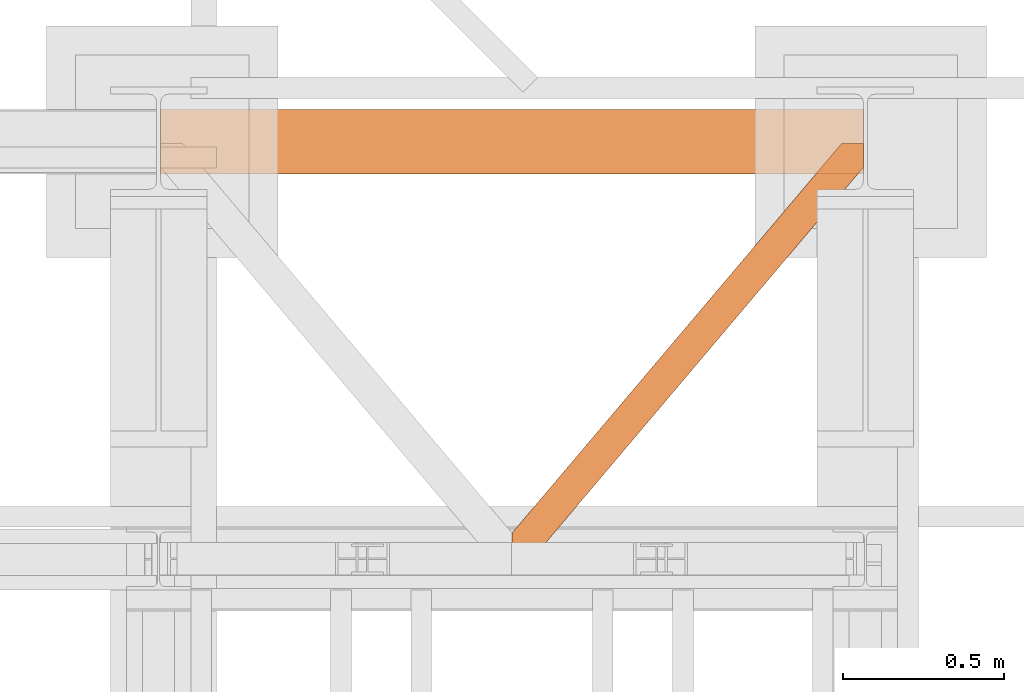
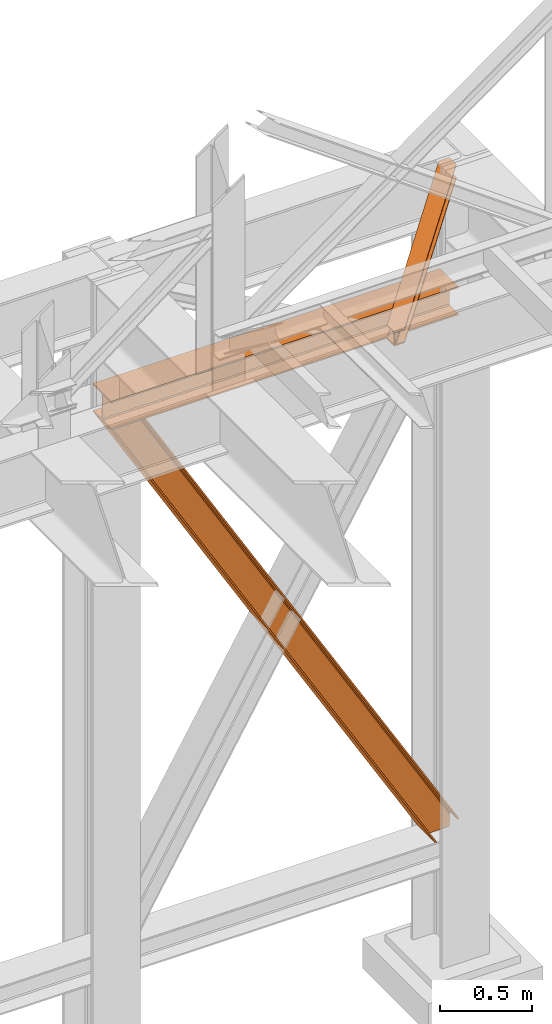
# One storey, part 198 of 208: 3 proxies.
"""IFC2X3 building model written with IfcOpenShell, lengths in millimetres."""

import ifcopenshell
import ifcopenshell.guid

model = None  # the IFC model being written
_history = None  # IfcOwnerHistory: only IFC2X3 demands one
_inside = {}  # id of a spatial element -> (the spatial element, [elements in it])
_under = {}  # id of a project, library or spatial element -> (it, [spatial elements below it])
_declared = {}  # id of a project -> (the project, [libraries it declares])
_typed = {}  # id of a type object -> (the type object, [elements of that type])
_made_of = {}  # id of a material, layer set ... -> (it, [elements and type objects made of it])


def new_model(schema):
    """Start an empty IFC model of exactly this schema.

    Asked for "IFC4X3", IfcOpenShell would pick the latest addendum, in which some entities
    have other attributes; the version numbers below select the first issue.
    IFC2X3 requires an IfcOwnerHistory on every rooted entity: one is made here for all.
    """
    global model, _history
    if schema == "IFC4X3":
        model = ifcopenshell.file(schema_version=(4, 3, 0, 0))
    else:
        model = ifcopenshell.file(schema=schema)
    _inside.clear()
    _under.clear()
    _declared.clear()
    _typed.clear()
    _made_of.clear()
    _history = None
    if model.schema == "IFC2X3":
        org = make("IfcOrganization", Name="unknown")
        user = make(
            "IfcPersonAndOrganization",
            ThePerson=make("IfcPerson", FamilyName="unknown"),
            TheOrganization=org,
        )
        app = make(
            "IfcApplication",
            ApplicationDeveloper=org,
            Version="unknown",
            ApplicationFullName="unknown",
            ApplicationIdentifier="unknown",
        )
        _history = make(
            "IfcOwnerHistory",
            OwningUser=user,
            OwningApplication=app,
            ChangeAction="ADDED",
            CreationDate=0,
        )
    return model


def make(cls, **values):
    """One entity of the class cls with the attributes given. An attribute that is None is left unset."""
    return model.create_entity(
        cls, **{name: value for name, value in values.items() if value is not None}
    )


def entity(cls, *values):
    """Any entity or typed value of the class cls, its attributes in the order of the schema. None: left unset."""
    e = model.create_entity(cls)
    for i, value in enumerate(values):
        if value is not None:
            e[i] = value
    return e


def rooted(cls, **values):
    """An entity with a GlobalId (a new one), such as an element, a storey or a relation."""
    return make(cls, GlobalId=ifcopenshell.guid.new(), OwnerHistory=_history, **values)


def si_unit(unit_type, name, prefix=None):
    """IfcSIUnit, for example si_unit("LENGTHUNIT", "METRE", prefix="MILLI")."""
    return make("IfcSIUnit", UnitType=unit_type, Prefix=prefix, Name=name)


def converted_unit(unit_type, name, factor, base, dimensions=None, offset=None):
    """IfcConversionBasedUnit, such as the inch: factor (a typed value) times the base unit."""
    return make(
        "IfcConversionBasedUnit"
        if offset is None
        else "IfcConversionBasedUnitWithOffset",
        ConversionOffset=offset,
        Dimensions=None
        if dimensions is None
        else entity("IfcDimensionalExponents", *dimensions),
        UnitType=unit_type,
        Name=name,
        ConversionFactor=make(
            "IfcMeasureWithUnit", ValueComponent=factor, UnitComponent=base
        ),
    )


def assignment(units):
    """IfcUnitAssignment: the units of a project."""
    return None if units is None else make("IfcUnitAssignment", Units=units)


def point(xyz):
    """IfcCartesianPoint."""
    return None if xyz is None else make("IfcCartesianPoint", Coordinates=xyz)


def direction(xyz):
    """IfcDirection."""
    return None if xyz is None else make("IfcDirection", DirectionRatios=xyz)


def frame(location, z_axis=None, x_axis=None):
    """IfcAxis2Placement3D, a coordinate frame: its origin and axes. An axis left out is left unset."""
    return make(
        "IfcAxis2Placement3D",
        Location=point(location),
        Axis=direction(z_axis),
        RefDirection=direction(x_axis),
    )


def origin():
    """The frame at (0, 0, 0) with its axes left unset."""
    return frame((0.0, 0.0, 0.0))


def origin_with_axes():
    """The frame at (0, 0, 0) with the z axis (0, 0, 1) and the x axis (1, 0, 0) written out."""
    return frame((0.0, 0.0, 0.0), z_axis=(0.0, 0.0, 1.0), x_axis=(1.0, 0.0, 0.0))


def place(relative_to, where):
    """IfcLocalPlacement: puts the frame where relative to a parent placement (None: the world)."""
    return make(
        "IfcLocalPlacement", PlacementRelTo=relative_to, RelativePlacement=where
    )


def context(
    kind, dimensions, precision=None, world=None, true_north=None, identifier=None
):
    """IfcGeometricRepresentationContext, for example the 3D "Model" context."""
    return make(
        "IfcGeometricRepresentationContext",
        ContextIdentifier=identifier,
        ContextType=kind,
        CoordinateSpaceDimension=dimensions,
        Precision=precision,
        WorldCoordinateSystem=world,
        TrueNorth=true_north,
    )


def subcontext(parent, identifier, kind, view, scale=None):
    """IfcGeometricRepresentationSubContext, for example "Body" below "Model"."""
    return make(
        "IfcGeometricRepresentationSubContext",
        ContextIdentifier=identifier,
        ContextType=kind,
        ParentContext=parent,
        TargetScale=scale,
        TargetView=view,
    )


def project(units=None, contexts=None):
    """IfcProject with its units and contexts."""
    return rooted(
        "IfcProject",
        Name="project",
        RepresentationContexts=contexts,
        UnitsInContext=assignment(units),
    )


def spatial(cls, under=None, at=None, **own):
    """A site, building, storey or space (cls), placed at a placement, below another one or the project."""
    s = rooted(cls, ObjectPlacement=at, **own)
    if under is not None:
        _under.setdefault(under.id(), (under, []))[1].append(s)
    return s


def faces_of(points, faces, orient=None, outer=None):
    """IfcFace entities. A face is a list of loops; a loop is a list of indices into points, from 0.

    orient and outer hold one flag for each loop. By default every Orientation is true, the
    first loop of a face is its IfcFaceOuterBound and the others are IfcFaceBound.
    """
    made = []
    for i, loops in enumerate(faces):
        bounds = []
        for j, loop in enumerate(loops):
            is_outer = j == 0 if outer is None else outer[i][j]
            bounds.append(
                make(
                    "IfcFaceOuterBound" if is_outer else "IfcFaceBound",
                    Bound=make("IfcPolyLoop", Polygon=[points[k] for k in loop]),
                    Orientation=True if orient is None else orient[i][j],
                )
            )
        made.append(make("IfcFace", Bounds=bounds))
    return made


def faceted_brep(points, faces, orient=None, outer=None, voids=None):
    """IfcFacetedBrep: a solid bounded by flat faces; with voids (closed shells), ...WithVoids."""
    shared = [point(p) for p in points]
    hull = make("IfcClosedShell", CfsFaces=faces_of(shared, faces, orient, outer))
    if voids is None:
        return make("IfcFacetedBrep", Outer=hull)
    return make(
        "IfcFacetedBrepWithVoids",
        Outer=hull,
        Voids=[
            make(cls, CfsFaces=faces_of(shared, fs, o, b)) for cls, fs, o, b in voids
        ],
    )


def shape(context_of_items, identifier, shape_type, items):
    """IfcShapeRepresentation: the items that make up one representation, for example the "Body"."""
    return make(
        "IfcShapeRepresentation",
        ContextOfItems=context_of_items,
        RepresentationIdentifier=identifier,
        RepresentationType=shape_type,
        Items=items,
    )


def made_of(thing, what):
    """Note that an element or type object is made of a material, layer set ...; save() writes the relation."""
    if what is not None:
        _made_of.setdefault(what.id(), (what, []))[1].append(thing)
    return thing


def element(
    cls,
    number,
    at=None,
    inside=None,
    cuts=None,
    type_object=None,
    material=None,
    context=None,
    identifier="Body",
    shape_type=None,
    held_by="IfcProductDefinitionShape",
    body=None,
    shapes=None,
    **own,
):
    """One element of the class cls, such as IfcWall. Its Tag is "e" and its number.

    at: its placement. inside: the storey or other place that contains it. cuts: it is an
    opening in that element (IfcRelVoidsElement). A single representation is given by context,
    identifier, shape_type and body (its items); several are given by shapes. held_by: the class
    of the entity that holds the representations. save() writes the other relations.
    """
    e = rooted(cls, Tag="e%d" % number, ObjectPlacement=at, **own)
    if body is not None:
        shapes = [shape(context, identifier, shape_type, body)]
    if shapes is not None:
        e.Representation = make(held_by, Representations=shapes)
    if inside is not None:
        _inside.setdefault(inside.id(), (inside, []))[1].append(e)
    if cuts is not None:
        rooted(
            "IfcRelVoidsElement", RelatingBuildingElement=cuts, RelatedOpeningElement=e
        )
    if type_object is not None:
        _typed.setdefault(type_object.id(), (type_object, []))[1].append(e)
    return made_of(e, material)


def aggregate(whole, parts):
    """IfcRelAggregates: a whole, such as a stair, and the parts it consists of."""
    return rooted("IfcRelAggregates", RelatingObject=whole, RelatedObjects=parts)


def save(model, path):
    """Write the relations noted so far, then the file.

    IfcRelAggregates (storeys below a building ...), IfcRelContainedInSpatialStructure (elements
    in a storey), IfcRelDefinesByType, IfcRelAssociatesMaterial and IfcRelDeclares: one each for
    every whole, place, type object, material and project.
    """
    for whole, parts in _under.values():
        aggregate(whole, parts)
    for where, things in _inside.values():
        rooted(
            "IfcRelContainedInSpatialStructure",
            RelatedElements=things,
            RelatingStructure=where,
        )
    for kind, things in _typed.values():
        rooted("IfcRelDefinesByType", RelatedObjects=things, RelatingType=kind)
    for what, things in _made_of.values():
        rooted("IfcRelAssociatesMaterial", RelatedObjects=things, RelatingMaterial=what)
    for by, libraries in _declared.values():
        rooted("IfcRelDeclares", RelatingContext=by, RelatedDefinitions=libraries)
    model.write(path)


model = new_model("IFC2X3")

# Units and contexts
model_context = context("Model", 3, precision=1e-05, world=origin())
plan_context = context("Plan", 3, precision=1e-05, world=origin())
body_context = subcontext(model_context, "Body", "Model", "MODEL_VIEW")
ifc_project = project(units=[si_unit("LENGTHUNIT", "METRE", prefix="MILLI"), converted_unit("PLANEANGLEUNIT", "DEGREE", entity("IfcPlaneAngleMeasure", 0.0174532925199433), si_unit("PLANEANGLEUNIT", "RADIAN"), dimensions=[0, 0, 0, 0, 0, 0, 0]), si_unit("AREAUNIT", "SQUARE_METRE"), si_unit("VOLUMEUNIT", "CUBIC_METRE")], contexts=[model_context, plan_context])

# Building, storey
building_placement = place(None, origin())
building = spatial("IfcBuilding", under=ifc_project, at=building_placement, CompositionType="COMPLEX")
storey_placement = place(building_placement, origin_with_axes())
storey = spatial("IfcBuildingStorey", under=building, at=storey_placement, Name="Geschoss", CompositionType="ELEMENT")

# Proxies
proxy_1_placement = place(storey_placement, frame((6599.254968580823, -12562.57439501764, 4202.989992847441), z_axis=(0.0, 0.0, 1.0), x_axis=(1.0, 0.0, 0.0)))
element("IfcBuildingElementProxy", 1, at=proxy_1_placement, inside=storey, context=body_context, shape_type="Brep", body=[
    faceted_brep([(2188.00999989569, 0.01000000000021828, 190.0100125169756), (2188.00999989569, 200.0100029802325, 190.0100125169756), (2188.00999989569, 200.0100029802325, 180.0100146031382), (2188.00999989569, 121.2600035762789, 180.0100071525576), (2188.00999989569, 111.9441915473344, 178.1454621052744), (2188.00999989569, 105.1245498640838, 171.3258190250399), (2188.00999989569, 103.2600015571716, 162.010007927418), (2188.00999989569, 103.2600015571716, 28.00999713897727), (2188.00999989569, 105.1245498640838, 18.69418604135535), (2188.00999989569, 111.9441915473344, 11.87454296112082), (2188.00999989569, 121.2600035762789, 10.00999791383765), (2188.00999989569, 200.0100029802325, 10.00999791383765), (2188.00999989569, 200.0100029802325, 0.01000000000021828), (2188.00999989569, 0.01000000000021828, 0.01000000000021828), (2188.00999989569, 0.01000000000021828, 10.00999791383765), (2188.00999989569, 78.75999940395377, 10.00999791383765), (2188.00999989569, 88.07581143289826, 11.87454296112082), (2188.00999989569, 94.89545311614893, 18.69418604135535), (2188.00999989569, 96.76000142306111, 28.00999713897727), (2188.00999989569, 96.76000142306111, 162.010007927418), (2188.00999989569, 94.89545311614893, 171.3258190250399), (2188.00999989569, 88.07581143289826, 178.1454621052744), (2188.00999989569, 78.75999940395377, 180.0100071525576), (2188.00999989569, 0.01000000000021828, 180.0100146031382), (2188.00999989569, 200.0100029802325, 190.0100125169756), (2188.00999989569, 0.01000000000021828, 190.0100125169756), (0.01000000000021828, 0.01000000000021828, 190.0100125169756), (0.01000000000021828, 200.0100029802325, 190.0100125169756), (2188.00999989569, 200.0100029802325, 180.0100146031382), (2188.00999989569, 200.0100029802325, 190.0100125169756), (0.01000000000021828, 200.0100029802325, 190.0100125169756), (0.01000000000021828, 200.0100029802325, 180.0100146031382), (2188.00999989569, 121.2600035762789, 180.0100071525576), (2188.00999989569, 200.0100029802325, 180.0100146031382), (0.01000000000021828, 200.0100029802325, 180.0100146031382), (0.01000000000021828, 121.2600035762789, 180.0100071525576), (2188.00999989569, 111.9441915473344, 178.1454621052744), (2188.00999989569, 121.2600035762789, 180.0100071525576), (0.01000000000021828, 121.2600035762789, 180.0100071525576), (0.01000000000021828, 111.9441915473344, 178.1454621052744), (2188.00999989569, 105.1245498640838, 171.3258190250399), (2188.00999989569, 111.9441915473344, 178.1454621052744), (0.01000000000021828, 111.9441915473344, 178.1454621052744), (0.01000000000021828, 105.1245498640838, 171.3258190250399), (2188.00999989569, 103.2600015571716, 162.010007927418), (2188.00999989569, 105.1245498640838, 171.3258190250399), (0.01000000000021828, 105.1245498640838, 171.3258190250399), (0.01000000000021828, 103.2600015571716, 162.010007927418), (2188.00999989569, 103.2600015571716, 28.00999713897727), (2188.00999989569, 103.2600015571716, 162.010007927418), (0.01000000000021828, 103.2600015571716, 162.010007927418), (0.01000000000021828, 103.2600015571716, 28.00999713897727), (2188.00999989569, 105.1245498640838, 18.69418604135535), (2188.00999989569, 103.2600015571716, 28.00999713897727), (0.01000000000021828, 103.2600015571716, 28.00999713897727), (0.01000000000021828, 105.1245498640838, 18.69418604135535), (2188.00999989569, 111.9441915473344, 11.87454296112082), (2188.00999989569, 105.1245498640838, 18.69418604135535), (0.01000000000021828, 105.1245498640838, 18.69418604135535), (0.01000000000021828, 111.9441915473344, 11.87454296112082), (2188.00999989569, 121.2600035762789, 10.00999791383765), (2188.00999989569, 111.9441915473344, 11.87454296112082), (0.01000000000021828, 111.9441915473344, 11.87454296112082), (0.01000000000021828, 121.2600035762789, 10.00999791383765), (2188.00999989569, 200.0100029802325, 10.00999791383765), (2188.00999989569, 121.2600035762789, 10.00999791383765), (0.01000000000021828, 121.2600035762789, 10.00999791383765), (0.01000000000021828, 200.0100029802325, 10.00999791383765), (2188.00999989569, 200.0100029802325, 0.01000000000021828), (2188.00999989569, 200.0100029802325, 10.00999791383765), (0.01000000000021828, 200.0100029802325, 10.00999791383765), (0.01000000000021828, 200.0100029802325, 0.01000000000021828), (2188.00999989569, 0.01000000000021828, 0.01000000000021828), (2188.00999989569, 200.0100029802325, 0.01000000000021828), (0.01000000000021828, 200.0100029802325, 0.01000000000021828), (0.01000000000021828, 0.01000000000021828, 0.01000000000021828), (2188.00999989569, 0.01000000000021828, 10.00999791383765), (2188.00999989569, 0.01000000000021828, 0.01000000000021828), (0.01000000000021828, 0.01000000000021828, 0.01000000000021828), (0.01000000000021828, 0.01000000000021828, 10.00999791383765), (2188.00999989569, 78.75999940395377, 10.00999791383765), (2188.00999989569, 0.01000000000021828, 10.00999791383765), (0.01000000000021828, 0.01000000000021828, 10.00999791383765), (0.01000000000021828, 78.75999940395377, 10.00999791383765), (2188.00999989569, 88.07581143289826, 11.87454296112082), (2188.00999989569, 78.75999940395377, 10.00999791383765), (0.01000000000021828, 78.75999940395377, 10.00999791383765), (0.01000000000021828, 88.07581143289826, 11.87454296112082), (2188.00999989569, 94.89545311614893, 18.69418604135535), (2188.00999989569, 88.07581143289826, 11.87454296112082), (0.01000000000021828, 88.07581143289826, 11.87454296112082), (0.01000000000021828, 94.89545311614893, 18.69418604135535), (2188.00999989569, 96.76000142306111, 28.00999713897727), (2188.00999989569, 94.89545311614893, 18.69418604135535), (0.01000000000021828, 94.89545311614893, 18.69418604135535), (0.01000000000021828, 96.76000142306111, 28.00999713897727), (2188.00999989569, 96.76000142306111, 162.010007927418), (2188.00999989569, 96.76000142306111, 28.00999713897727), (0.01000000000021828, 96.76000142306111, 28.00999713897727), (0.01000000000021828, 96.76000142306111, 162.010007927418), (2188.00999989569, 94.89545311614893, 171.3258190250399), (2188.00999989569, 96.76000142306111, 162.010007927418), (0.01000000000021828, 96.76000142306111, 162.010007927418), (0.01000000000021828, 94.89545311614893, 171.3258190250399), (2188.00999989569, 88.07581143289826, 178.1454621052744), (2188.00999989569, 94.89545311614893, 171.3258190250399), (0.01000000000021828, 94.89545311614893, 171.3258190250399), (0.01000000000021828, 88.07581143289826, 178.1454621052744), (2188.00999989569, 78.75999940395377, 180.0100071525576), (2188.00999989569, 88.07581143289826, 178.1454621052744), (0.01000000000021828, 88.07581143289826, 178.1454621052744), (0.01000000000021828, 78.75999940395377, 180.0100071525576), (2188.00999989569, 0.01000000000021828, 180.0100146031382), (2188.00999989569, 78.75999940395377, 180.0100071525576), (0.01000000000021828, 78.75999940395377, 180.0100071525576), (0.01000000000021828, 0.01000000000021828, 180.0100146031382), (2188.00999989569, 0.01000000000021828, 190.0100125169756), (2188.00999989569, 0.01000000000021828, 180.0100146031382), (0.01000000000021828, 0.01000000000021828, 180.0100146031382), (0.01000000000021828, 0.01000000000021828, 190.0100125169756), (0.01000000000021828, 0.01000000000021828, 190.0100125169756), (0.01000000000021828, 0.01000000000021828, 180.0100146031382), (0.01000000000021828, 78.75999940395377, 180.0100071525576), (0.01000000000021828, 88.07581143289826, 178.1454621052744), (0.01000000000021828, 94.89545311614893, 171.3258190250399), (0.01000000000021828, 96.76000142306111, 162.010007927418), (0.01000000000021828, 96.76000142306111, 28.00999713897727), (0.01000000000021828, 94.89545311614893, 18.69418604135535), (0.01000000000021828, 88.07581143289826, 11.87454296112082), (0.01000000000021828, 78.75999940395377, 10.00999791383765), (0.01000000000021828, 0.01000000000021828, 10.00999791383765), (0.01000000000021828, 0.01000000000021828, 0.01000000000021828), (0.01000000000021828, 200.0100029802325, 0.01000000000021828), (0.01000000000021828, 200.0100029802325, 10.00999791383765), (0.01000000000021828, 121.2600035762789, 10.00999791383765), (0.01000000000021828, 111.9441915473344, 11.87454296112082), (0.01000000000021828, 105.1245498640838, 18.69418604135535), (0.01000000000021828, 103.2600015571716, 28.00999713897727), (0.01000000000021828, 103.2600015571716, 162.010007927418), (0.01000000000021828, 105.1245498640838, 171.3258190250399), (0.01000000000021828, 111.9441915473344, 178.1454621052744), (0.01000000000021828, 121.2600035762789, 180.0100071525576), (0.01000000000021828, 200.0100029802325, 180.0100146031382), (0.01000000000021828, 200.0100029802325, 190.0100125169756)], [[[0, 1, 2, 3, 4, 5, 6, 7, 8, 9, 10, 11, 12, 13, 14, 15, 16, 17, 18, 19, 20, 21, 22, 23]], [[24, 25, 26, 27]], [[28, 29, 30, 31]], [[32, 33, 34, 35]], [[36, 37, 38, 39]], [[40, 41, 42, 43]], [[44, 45, 46, 47]], [[48, 49, 50, 51]], [[52, 53, 54, 55]], [[56, 57, 58, 59]], [[60, 61, 62, 63]], [[64, 65, 66, 67]], [[68, 69, 70, 71]], [[72, 73, 74, 75]], [[76, 77, 78, 79]], [[80, 81, 82, 83]], [[84, 85, 86, 87]], [[88, 89, 90, 91]], [[92, 93, 94, 95]], [[96, 97, 98, 99]], [[100, 101, 102, 103]], [[104, 105, 106, 107]], [[108, 109, 110, 111]], [[112, 113, 114, 115]], [[116, 117, 118, 119]], [[120, 121, 122, 123, 124, 125, 126, 127, 128, 129, 130, 131, 132, 133, 134, 135, 136, 137, 138, 139, 140, 141, 142, 143]]], orient=[[False], [False], [False], [False], [False], [False], [False], [False], [False], [False], [False], [False], [False], [False], [False], [False], [False], [False], [False], [False], [False], [False], [False], [False], [False], [False]]),
])
proxy_2_placement = place(storey_placement, frame((7693.25496852868, -13757.87439038569, 5101.99001616488), z_axis=(0.0, 0.0, 1.0), x_axis=(1.0, 0.0, 0.0)))
element("IfcBuildingElementProxy", 2, at=proxy_2_placement, inside=storey, context=body_context, shape_type="Brep", body=[
    faceted_brep([(65.50764084493949, 0.01000000000021828, 8.010001311303313), (1094.009999947833, 1215.512788030695, 8.010001311302403), (1094.009999947833, 1215.512788030695, 0.01000000000112777), (65.50764084493949, 0.01000000000021828, 0.01000000000112777), (65.50764084493949, 0.01000000000021828, 0.01000000000112777), (1094.009999947833, 1215.512788030695, 0.01000000000112777), (1094.009999947833, 1290.610003345231, 0.01000000000021828), (1026.558515831797, 1290.610003345231, 0.01000000000021828), (0.01000000000203727, 77.4163028167477, 0.01000000000112777), (0.01000000000203727, 0.01000000000021828, 0.01000000000112777), (0.01000000000203727, 77.4163028167477, 0.01000000000112777), (1026.558515831797, 1290.610003345231, 0.01000000000021828), (1026.558515831797, 1290.610003345231, 8.010001311303313), (0.01000000000112777, 77.4163028167477, 8.010001311303313), (0.01000000000112777, 77.4163028167477, 8.010001311303313), (1026.558515831797, 1290.610003345231, 8.010001311303313), (1073.061840441305, 1290.610003345231, 8.010001311303313), (0.01000000000203727, 22.45782827823678, 8.010001311303313), (0.01000000000203727, 22.45782827823678, 8.010001311303313), (1073.061840441305, 1290.610003345231, 8.010001311303313), (1081.19735523943, 1290.610003345231, 9.253033826352294), (0.01000000000203727, 12.84312897136078, 9.253033826352294), (0.01000000000203727, 12.84312897136078, 9.253033826352294), (1081.19735523943, 1290.610003345231, 9.253033826352294), (1087.152961141161, 1290.610003345231, 13.79946006298178), (0.01000000000203727, 5.804685632951077, 13.79946006298178), (0.01000000000203727, 5.804685632951077, 13.79946006298178), (1087.152961141161, 1290.610003345231, 13.79946006298178), (1088.781274451487, 1290.610003345231, 20.01000141561144), (0.01000000000203727, 3.880315357111613, 20.01000141561144), (0.01000000000203727, 3.880315357111613, 20.01000141561144), (1088.781274451487, 1290.610003345231, 20.01000141561144), (1088.781274451487, 1290.610003345231, 76.01000128150099), (0.01000000000203727, 3.880315357111613, 76.01000128150099), (0.01000000000203727, 3.880315357111613, 76.01000128150099), (1088.781274451487, 1290.610003345231, 76.01000128150099), (1087.152961141161, 1290.610003345231, 82.2205407714855), (0.01000000000203727, 5.804685632951077, 82.2205407714855), (0.01000000000203727, 5.804685632951077, 82.2205407714855), (1087.152961141161, 1290.610003345231, 82.2205407714855), (1081.19735523943, 1290.610003345231, 86.76696700811499), (0.01000000000203727, 12.84312897136078, 86.76696700811499), (0.01000000000203727, 12.84312897136078, 86.76696700811499), (1081.19735523943, 1290.610003345231, 86.76696700811499), (1073.061840441305, 1290.610003345231, 88.00999952316397), (0.01000000000203727, 22.45782827823678, 88.00999952316397), (0.01000000000203727, 22.45782827823678, 88.00999952316397), (1073.061840441305, 1290.610003345231, 88.00999952316397), (1026.558515831795, 1290.610003345231, 88.00999952316397), (0.01000000000203727, 77.4163028167477, 88.00999952316397), (0.01000000000203727, 77.4163028167477, 88.00999952316397), (1026.558515831795, 1290.610003345231, 88.00999952316397), (1026.558515831795, 1290.610003345231, 96.01000083446615), (0.01000000000021828, 77.41630281674588, 96.01000083446615), (0.01000000000021828, 77.41630281674588, 96.01000083446615), (1026.558515831795, 1290.610003345231, 96.01000083446615), (1094.009999947833, 1290.610003345231, 96.01000083446615), (1094.009999947833, 1215.512788030695, 96.01000083446615), (65.50764084493858, 0.01000000000021828, 96.01000083446615), (0.01000000000021828, 0.01000000000021828, 96.01000083446615), (65.50764084493858, 0.01000000000021828, 96.01000083446615), (1094.009999947833, 1215.512788030695, 96.01000083446615), (1094.009999947833, 1215.512788030695, 88.00999952316397), (65.50764084493858, 0.01000000000021828, 88.00999952316397), (65.50764084493858, 0.01000000000021828, 88.00999952316397), (1094.009999947833, 1215.512788030695, 88.00999952316397), (1094.009999947833, 1270.47126256921, 88.00999952316397), (19.00431623542681, 0.01000000000021828, 88.00999952316397), (19.00431623542681, 0.01000000000021828, 88.00999952316397), (1094.009999947833, 1270.47126256921, 88.00999952316397), (1094.009999947833, 1280.085961876086, 86.76696700811499), (10.86880143730195, 0.01000000000021828, 86.76696700811499), (10.86880143730195, 0.01000000000021828, 86.76696700811499), (1094.009999947833, 1280.085961876086, 86.76696700811499), (1094.009999947833, 1287.124405214492, 82.2205407714855), (4.913195535572413, 0.01000000000021828, 82.2205407714855), (4.913195535572413, 0.01000000000021828, 82.2205407714855), (1094.009999947833, 1287.124405214492, 82.2205407714855), (1094.009999947833, 1289.048775490333, 76.01000128150099), (3.284882225245383, 0.01000000000021828, 76.01000128150099), (3.284882225245383, 0.01000000000021828, 76.01000128150099), (1094.009999947833, 1289.048775490333, 76.01000128150099), (1094.009999947833, 1289.048775490333, 20.01000141561144), (3.284882225245383, 0.01000000000021828, 20.01000141561144), (3.284882225245383, 0.01000000000021828, 20.01000141561144), (1094.009999947833, 1289.048775490333, 20.01000141561144), (1094.009999947835, 1287.124405214492, 13.79946006298178), (4.913195535571504, 0.01000000000021828, 13.79946006298178), (4.913195535571504, 0.01000000000021828, 13.79946006298178), (1094.009999947835, 1287.124405214492, 13.79946006298178), (1094.009999947833, 1280.085961876082, 9.253033826352294), (10.86880143730286, 0.01000000000021828, 9.253033826352294), (10.86880143730286, 0.01000000000021828, 9.253033826352294), (1094.009999947833, 1280.085961876082, 9.253033826352294), (1094.009999947833, 1270.47126256921, 8.010001311303313), (19.00431623542863, 0.01000000000021828, 8.010001311303313), (19.00431623542863, 0.01000000000021828, 8.010001311303313), (1094.009999947833, 1270.47126256921, 8.010001311303313), (1094.009999947833, 1215.512788030695, 8.010001311302403), (65.50764084493949, 0.01000000000021828, 8.010001311303313), (0.01000000000203727, 77.4163028167477, 0.01000000000112777), (0.01000000000112777, 77.4163028167477, 8.010001311303313), (0.01000000000203727, 22.45782827823678, 8.010001311303313), (0.01000000000203727, 12.84312897136078, 9.253033826352294), (0.01000000000203727, 5.804685632951077, 13.79946006298178), (0.01000000000203727, 3.880315357111613, 20.01000141561144), (0.01000000000203727, 3.880315357111613, 76.01000128150099), (0.01000000000203727, 5.804685632951077, 82.2205407714855), (0.01000000000203727, 12.84312897136078, 86.76696700811499), (0.01000000000203727, 22.45782827823678, 88.00999952316397), (0.01000000000203727, 77.4163028167477, 88.00999952316397), (0.01000000000021828, 77.41630281674588, 96.01000083446615), (0.01000000000021828, 0.01000000000021828, 96.01000083446615), (0.01000000000203727, 0.01000000000021828, 0.01000000000112777), (0.01000000000021828, 0.01000000000021828, 96.01000083446615), (65.50764084493858, 0.01000000000021828, 96.01000083446615), (65.50764084493858, 0.01000000000021828, 88.00999952316397), (19.00431623542681, 0.01000000000021828, 88.00999952316397), (10.86880143730195, 0.01000000000021828, 86.76696700811499), (4.913195535572413, 0.01000000000021828, 82.2205407714855), (3.284882225245383, 0.01000000000021828, 76.01000128150099), (3.284882225245383, 0.01000000000021828, 20.01000141561144), (4.913195535571504, 0.01000000000021828, 13.79946006298178), (10.86880143730286, 0.01000000000021828, 9.253033826352294), (19.00431623542863, 0.01000000000021828, 8.010001311303313), (65.50764084493949, 0.01000000000021828, 8.010001311303313), (65.50764084493949, 0.01000000000021828, 0.01000000000112777), (0.01000000000203727, 0.01000000000021828, 0.01000000000112777), (1094.009999947833, 1215.512788030695, 8.010001311302403), (1094.009999947833, 1270.47126256921, 8.010001311303313), (1094.009999947833, 1280.085961876082, 9.253033826352294), (1094.009999947835, 1287.124405214492, 13.79946006298178), (1094.009999947833, 1289.048775490333, 20.01000141561144), (1094.009999947833, 1289.048775490333, 76.01000128150099), (1094.009999947833, 1287.124405214492, 82.2205407714855), (1094.009999947833, 1280.085961876086, 86.76696700811499), (1094.009999947833, 1270.47126256921, 88.00999952316397), (1094.009999947833, 1215.512788030695, 88.00999952316397), (1094.009999947833, 1215.512788030695, 96.01000083446615), (1094.009999947833, 1290.610003345231, 96.01000083446615), (1094.009999947833, 1290.610003345231, 0.01000000000021828), (1094.009999947833, 1215.512788030695, 0.01000000000112777), (1094.009999947833, 1290.610003345231, 0.01000000000021828), (1094.009999947833, 1290.610003345231, 96.01000083446615), (1026.558515831795, 1290.610003345231, 96.01000083446615), (1026.558515831795, 1290.610003345231, 88.00999952316397), (1073.061840441305, 1290.610003345231, 88.00999952316397), (1081.19735523943, 1290.610003345231, 86.76696700811499), (1087.152961141161, 1290.610003345231, 82.2205407714855), (1088.781274451487, 1290.610003345231, 76.01000128150099), (1088.781274451487, 1290.610003345231, 20.01000141561144), (1087.152961141161, 1290.610003345231, 13.79946006298178), (1081.19735523943, 1290.610003345231, 9.253033826352294), (1073.061840441305, 1290.610003345231, 8.010001311303313), (1026.558515831797, 1290.610003345231, 8.010001311303313), (1026.558515831797, 1290.610003345231, 0.01000000000021828)], [[[0, 1, 2, 3]], [[4, 5, 6, 7, 8, 9]], [[10, 11, 12, 13]], [[14, 15, 16, 17]], [[18, 19, 20, 21]], [[22, 23, 24, 25]], [[26, 27, 28, 29]], [[30, 31, 32, 33]], [[34, 35, 36, 37]], [[38, 39, 40, 41]], [[42, 43, 44, 45]], [[46, 47, 48, 49]], [[50, 51, 52, 53]], [[54, 55, 56, 57, 58, 59]], [[60, 61, 62, 63]], [[64, 65, 66, 67]], [[68, 69, 70, 71]], [[72, 73, 74, 75]], [[76, 77, 78, 79]], [[80, 81, 82, 83]], [[84, 85, 86, 87]], [[88, 89, 90, 91]], [[92, 93, 94, 95]], [[96, 97, 98, 99]], [[100, 101, 102, 103, 104, 105, 106, 107, 108, 109, 110, 111, 112, 113]], [[114, 115, 116, 117, 118, 119, 120, 121, 122, 123, 124, 125, 126, 127]], [[128, 129, 130, 131, 132, 133, 134, 135, 136, 137, 138, 139, 140, 141]], [[142, 143, 144, 145, 146, 147, 148, 149, 150, 151, 152, 153, 154, 155]]], orient=[[False], [False], [False], [False], [False], [False], [False], [False], [False], [False], [False], [False], [False], [False], [False], [False], [False], [False], [False], [False], [False], [False], [False], [False], [False], [False], [False], [False]]),
])
proxy_3_placement = place(storey_placement, frame((6599.832450539901, -12562.57439501764, 734.9900149335328), z_axis=(0.0, 0.0, 1.0), x_axis=(1.0, 0.0, 0.0)))
element("IfcBuildingElementProxy", 3, at=proxy_3_placement, inside=storey, context=body_context, shape_type="Brep", body=[
    faceted_brep([(2187.432517936612, 0.01000000000021828, 120.8497915510924), (216.8471928951321, 0.01000000000021828, 3468.009977913908), (216.8471928951321, 200.0100029802325, 3468.009977913908), (2187.432517936612, 200.0100029802325, 120.8497915510924), (2187.432517936612, 200.0100029802325, 120.8497915510924), (216.8471928951321, 200.0100029802325, 3468.009977913908), (205.4347121912169, 200.0100029802325, 3468.009977913908), (2187.432517936612, 200.0100029802325, 101.4682129393398), (2187.432517936612, 200.0100029802325, 101.4682129393398), (205.4347121912169, 200.0100029802325, 3468.009977913908), (205.4347036882537, 121.2600035762789, 3468.009977913908), (2187.432517936952, 121.2600035762789, 101.4681984983711), (2187.432517936952, 121.2600035762789, 101.4681984983711), (205.4347036882537, 121.2600035762789, 3468.009977913908), (203.3067948069675, 111.9441915473344, 3468.009977913909), (2187.432602958226, 111.9441915473344, 97.85427409430258), (2187.432602958226, 111.9441915473344, 97.85427409430258), (203.3067948069675, 111.9441915473344, 3468.009977913909), (195.5238886772495, 105.1245498640838, 3468.009977913908), (2187.432517936612, 105.1245498640838, 84.63689245399041), (2187.432517936612, 105.1245498640838, 84.63689245399041), (195.5238886772495, 105.1245498640838, 3468.009977913908), (184.892235020021, 103.2600015571716, 3468.009977913908), (2187.432517936612, 103.2600015571716, 66.58142866151923), (2187.432517936612, 103.2600015571716, 0.009999999999990905), (2187.432517936612, 103.2600015571716, 66.58142866151923), (184.892235020021, 103.2600015571716, 3468.009977913908), (31.96494937214811, 103.2600015571716, 3468.009977913908), (2073.723887154785, 103.2600015571716, 0.01000000000021828), (2073.723887154785, 103.2600015571716, 0.01000000000021828), (31.96494937214811, 103.2600015571716, 3468.009977913908), (21.33329571491959, 105.1245498640838, 3468.009977913908), (2063.093996904379, 105.1245498640838, 0.01000000000010459), (2063.093996904379, 105.1245498640838, 0.01000000000010459), (21.33329571491959, 105.1245498640838, 3468.009977913908), (13.55038958520254, 111.9441915473344, 3468.009977913908), (2055.312379673187, 111.9441915473344, 0.009999999999763531), (2055.312379673187, 111.9441915473344, 0.009999999999763531), (13.55038958520254, 111.9441915473344, 3468.009977913908), (11.42248070391543, 121.2600035762789, 3468.009977913907), (2053.184822892688, 121.2600035762789, 0.009999999999763531), (2053.184822892688, 121.2600035762789, 0.009999999999763531), (11.42248070391543, 121.2600035762789, 3468.009977913907), (11.42248070391634, 200.0100029802325, 3468.009977913907), (2053.184822892688, 200.0100029802325, 0.009999999999763531), (2053.184822892688, 200.0100029802325, 0.009999999999763531), (11.42248070391634, 200.0100029802325, 3468.009977913907), (0.01000000000021828, 200.0100029802325, 3468.009977913908), (2041.774228435659, 200.0100029802325, 0.009999999999990905), (2041.774228435659, 200.0100029802325, 0.009999999999990905), (0.01000000000021828, 200.0100029802325, 3468.009977913908), (0.01000000000021828, 0.01000000000021828, 3468.009977913908), (2041.774228435659, 0.01000000000021828, 0.009999999999990905), (2041.774228435659, 0.01000000000021828, 0.009999999999990905), (0.01000000000021828, 0.01000000000021828, 3468.009977913908), (11.42248070391725, 0.01000000000021828, 3468.009977913908), (2053.184822892688, 0.01000000000021828, 0.009999999999877218), (2053.184822892688, 0.01000000000021828, 0.009999999999877218), (11.42248070391725, 0.01000000000021828, 3468.009977913908), (11.42248070391634, 78.75999940395377, 3468.009977913907), (2053.184822892688, 78.75999940395377, 0.009999999999763531), (2053.184822892688, 78.75999940395377, 0.009999999999763531), (11.42248070391634, 78.75999940395377, 3468.009977913907), (13.55038958520254, 88.07581143290008, 3468.009977913908), (2055.312379673187, 88.07581143289826, 0.009999999999763531), (2055.312379673187, 88.07581143289826, 0.009999999999763531), (13.55038958520254, 88.07581143290008, 3468.009977913908), (21.33329571491959, 94.89545311614893, 3468.009977913908), (2063.093996904379, 94.89545311614893, 0.009999999999763531), (2063.093996904379, 94.89545311614893, 0.009999999999763531), (21.33329571491959, 94.89545311614893, 3468.009977913908), (31.96494937214811, 96.76000142306111, 3468.009977913908), (2073.723887154785, 96.76000142306111, 0.01000000000021828), (2073.723887154785, 96.76000142306111, 0.01000000000021828), (31.96494937214811, 96.76000142306111, 3468.009977913908), (184.892235020021, 96.76000142306111, 3468.009977913908), (2187.432517936612, 96.76000142306111, 66.58142866151888), (2187.432517936612, 96.76000142306111, 0.009999999999990905), (2187.432517936612, 96.76000142306111, 66.58142866151888), (184.892235020021, 96.76000142306111, 3468.009977913908), (195.5238886772495, 94.89545311614893, 3468.009977913908), (2187.432517936612, 94.89545311615075, 84.63689245399041), (2187.432517936612, 94.89545311615075, 84.63689245399041), (195.5238886772495, 94.89545311614893, 3468.009977913908), (203.3067948069675, 88.07581143289826, 3468.009977913909), (2187.432517936612, 88.07581143289826, 97.85441850857092), (2187.432517936612, 88.07581143289826, 97.85441850857092), (203.3067948069675, 88.07581143289826, 3468.009977913909), (205.4347036882546, 78.75999940395377, 3468.009977913908), (2187.432433072334, 78.75999940395377, 101.4683426459951), (2187.432433072334, 78.75999940395377, 101.4683426459951), (205.4347036882546, 78.75999940395377, 3468.009977913908), (205.4347121912169, 0.01000000000021828, 3468.009977913908), (2187.432517936273, 0.01000000000021828, 101.4682129399164), (2187.432517936273, 0.01000000000021828, 101.4682129399164), (205.4347121912169, 0.01000000000021828, 3468.009977913908), (216.8471928951321, 0.01000000000021828, 3468.009977913908), (2187.432517936612, 0.01000000000021828, 120.8497915510924), (216.8471928951321, 0.01000000000021828, 3468.009977913908), (205.4347121912169, 0.01000000000021828, 3468.009977913908), (205.4347036882546, 78.75999940395377, 3468.009977913908), (203.3067948069675, 88.07581143289826, 3468.009977913909), (195.5238886772495, 94.89545311614893, 3468.009977913908), (184.892235020021, 96.76000142306111, 3468.009977913908), (31.96494937214811, 96.76000142306111, 3468.009977913908), (21.33329571491959, 94.89545311614893, 3468.009977913908), (13.55038958520254, 88.07581143290008, 3468.009977913908), (11.42248070391634, 78.75999940395377, 3468.009977913907), (11.42248070391725, 0.01000000000021828, 3468.009977913908), (0.01000000000021828, 0.01000000000021828, 3468.009977913908), (0.01000000000021828, 200.0100029802325, 3468.009977913908), (11.42248070391634, 200.0100029802325, 3468.009977913907), (11.42248070391543, 121.2600035762789, 3468.009977913907), (13.55038958520254, 111.9441915473344, 3468.009977913908), (21.33329571491959, 105.1245498640838, 3468.009977913908), (31.96494937214811, 103.2600015571716, 3468.009977913908), (184.892235020021, 103.2600015571716, 3468.009977913908), (195.5238886772495, 105.1245498640838, 3468.009977913908), (203.3067948069675, 111.9441915473344, 3468.009977913909), (205.4347036882537, 121.2600035762789, 3468.009977913908), (205.4347121912169, 200.0100029802325, 3468.009977913908), (216.8471928951321, 200.0100029802325, 3468.009977913908), (2187.432517936612, 96.76000142306111, 0.009999999999990905), (2187.432517936612, 96.76000142306111, 66.58142866151888), (2187.432517936612, 94.89545311615075, 84.63689245399041), (2187.432517936612, 88.07581143289826, 97.85441850857092), (2187.432433072334, 78.75999940395377, 101.4683426459951), (2187.432517936273, 0.01000000000021828, 101.4682129399164), (2187.432517936612, 0.01000000000021828, 120.8497915510924), (2187.432517936612, 200.0100029802325, 120.8497915510924), (2187.432517936612, 200.0100029802325, 101.4682129393398), (2187.432517936952, 121.2600035762789, 101.4681984983711), (2187.432602958226, 111.9441915473344, 97.85427409430258), (2187.432517936612, 105.1245498640838, 84.63689245399041), (2187.432517936612, 103.2600015571716, 66.58142866151923), (2187.432517936612, 103.2600015571716, 0.009999999999990905), (2073.723887154785, 103.2600015571716, 0.01000000000021828), (2063.093996904379, 105.1245498640838, 0.01000000000010459), (2055.312379673187, 111.9441915473344, 0.009999999999763531), (2053.184822892688, 121.2600035762789, 0.009999999999763531), (2053.184822892688, 200.0100029802325, 0.009999999999763531), (2041.774228435659, 200.0100029802325, 0.009999999999990905), (2041.774228435659, 0.01000000000021828, 0.009999999999990905), (2053.184822892688, 0.01000000000021828, 0.009999999999877218), (2053.184822892688, 78.75999940395377, 0.009999999999763531), (2055.312379673187, 88.07581143289826, 0.009999999999763531), (2063.093996904379, 94.89545311614893, 0.009999999999763531), (2073.723887154785, 96.76000142306111, 0.01000000000021828), (2187.432517936612, 96.76000142306111, 0.009999999999990905), (2187.432517936612, 103.2600015571716, 0.009999999999990905)], [[[0, 1, 2, 3]], [[4, 5, 6, 7]], [[8, 9, 10, 11]], [[12, 13, 14, 15]], [[16, 17, 18, 19]], [[20, 21, 22, 23]], [[24, 25, 26, 27, 28]], [[29, 30, 31, 32]], [[33, 34, 35, 36]], [[37, 38, 39, 40]], [[41, 42, 43, 44]], [[45, 46, 47, 48]], [[49, 50, 51, 52]], [[53, 54, 55, 56]], [[57, 58, 59, 60]], [[61, 62, 63, 64]], [[65, 66, 67, 68]], [[69, 70, 71, 72]], [[73, 74, 75, 76, 77]], [[78, 79, 80, 81]], [[82, 83, 84, 85]], [[86, 87, 88, 89]], [[90, 91, 92, 93]], [[94, 95, 96, 97]], [[98, 99, 100, 101, 102, 103, 104, 105, 106, 107, 108, 109, 110, 111, 112, 113, 114, 115, 116, 117, 118, 119, 120, 121]], [[122, 123, 124, 125, 126, 127, 128, 129, 130, 131, 132, 133, 134, 135]], [[136, 137, 138, 139, 140, 141, 142, 143, 144, 145, 146, 147, 148, 149]]], orient=[[False], [False], [False], [False], [False], [False], [False], [False], [False], [False], [False], [False], [False], [False], [False], [False], [False], [False], [False], [False], [False], [False], [False], [False], [False], [False], [False]]),
])

save(model, "model.ifc")
